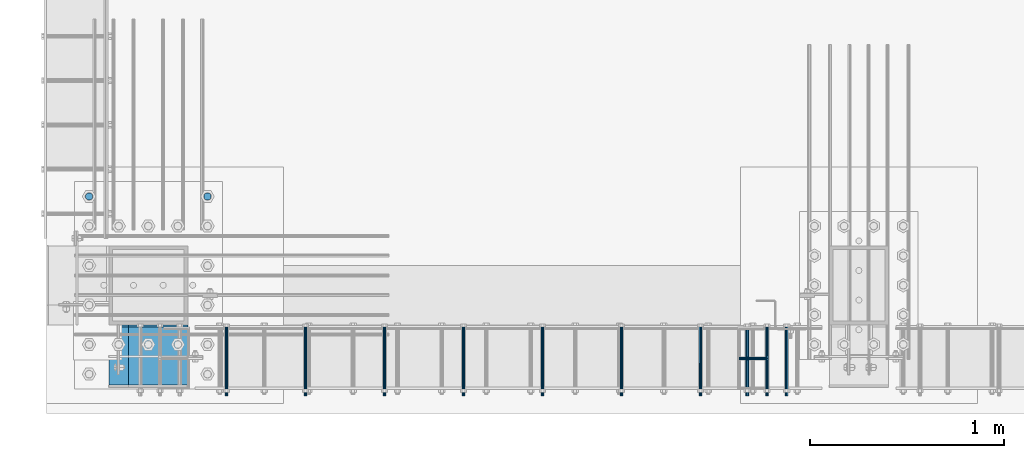
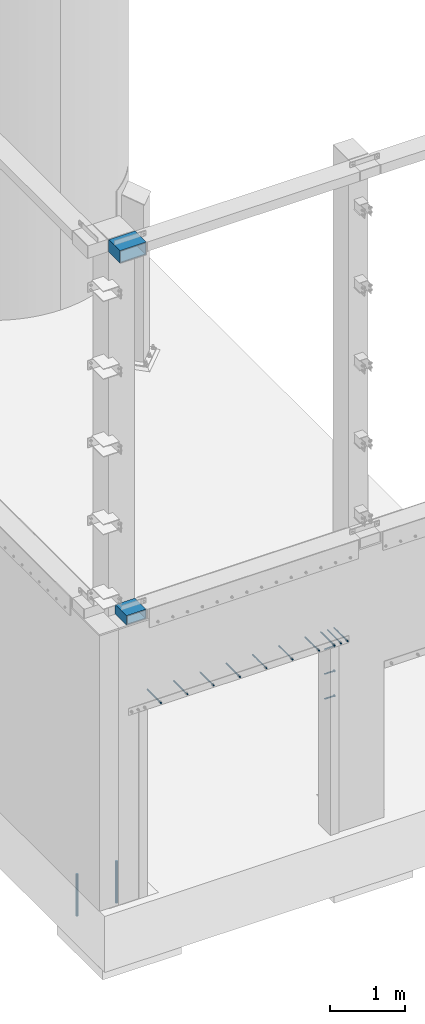
# One storey, part 1083 of 1876: 17 beams, 13 elements without a shape of their own.
"""IFC2X3 building model written with IfcOpenShell, lengths in millimetres."""

from ifc_helpers import new_model, si_unit, frame, origin_with_axes, place, context, subcontext, project, spatial, faceted_brep, material, type_object, element, aggregate, save


model = new_model("IFC2X3")

# Units and contexts
model_context = context("Model", 3, precision=1e-05, world=origin_with_axes())
body_context = subcontext(model_context, "Body", "Model", "MODEL_VIEW")
ifc_project = project(units=[si_unit("LENGTHUNIT", "METRE", prefix="MILLI"), si_unit("AREAUNIT", "SQUARE_METRE"), si_unit("VOLUMEUNIT", "CUBIC_METRE"), si_unit("MASSUNIT", "GRAM", prefix="KILO"), si_unit("TIMEUNIT", "SECOND"), si_unit("PLANEANGLEUNIT", "RADIAN"), si_unit("SOLIDANGLEUNIT", "STERADIAN"), si_unit("THERMODYNAMICTEMPERATUREUNIT", "DEGREE_CELSIUS"), si_unit("LUMINOUSINTENSITYUNIT", "LUMEN")], contexts=[model_context])

# Site, building, storey
site_placement = place(None, origin_with_axes())
site = spatial("IfcSite", under=ifc_project, at=site_placement, CompositionType="ELEMENT")
building_placement = place(site_placement, origin_with_axes())
building = spatial("IfcBuilding", under=site, at=building_placement, Name="Undefined", CompositionType="ELEMENT")
storey_placement = place(building_placement, origin_with_axes())
storey = spatial("IfcBuildingStorey", under=building, at=storey_placement, Name="Undefined", CompositionType="ELEMENT", Elevation=0.0)

# Assembly, beam
assembly_1_placement = place(storey_placement, origin_with_axes())
assembly_1 = element("IfcElementAssembly", 1, at=assembly_1_placement, inside=storey, Name="COLUMN", AssemblyPlace="NOTDEFINED", PredefinedType="RIGID_FRAME")
ifc_material_1 = material()
beam_type_1 = type_object("IfcBeamType", Name="HSS12X6X1/2", PredefinedType="NOTDEFINED")
beam_1_placement = place(assembly_1_placement, frame((282.574999999999, -25923.875, 4597.4), z_axis=(-1.0, 0.0, 0.0), x_axis=(0.0, 1.0, 0.0)))
beam_1 = element("IfcBeam", 2, at=beam_1_placement, type_object=beam_type_1, material=ifc_material_1, Name="BEAM", ObjectType="HSS12X6X1/2", context=body_context, shape_type="Brep", body=[
    faceted_brep([(9.52499999999452, -76.1999999999998, 152.400000000001), (9.52499999999452, -76.1999999999998, -152.400000000001), (307.975000000006, -76.1999999999998, -152.400000000001), (307.975000000006, -76.1999999999998, 152.400000000001), (9.52499999999452, 76.1999999999998, 152.400000000001), (9.52499999999452, 76.1999999999998, -152.400000000001), (9.52499999999452, 63.5, 139.700000000001), (9.52499999999452, -63.5, 139.700000000001), (9.52499999999452, -63.5, -139.700000000001), (9.52499999999452, 63.5, -139.700000000001), (320.675000000004, -63.5, 139.700000000001), (320.675000000004, -63.5, -139.700000000001), (320.675000000004, -63.5000000000018, -152.400000000001), (320.675000000004, -63.5000000000018, 152.400000000001), (320.675000000004, 63.5000000000073, 152.400000000001), (308.334731518538, 76.1999999999998, 152.4), (308.334731518538, 76.1999999999998, -152.4), (320.675000000004, 63.5000000000073, -152.400000000001), (320.675000000004, 63.5, -139.700000000001), (320.675000000004, 63.5, 139.700000000001)], [[[0, 1, 2, 3]], [[1, 0, 4, 5], [6, 7, 8, 9]], [[8, 7, 10, 11]], [[2, 12, 11, 10, 13, 3]], [[4, 0, 3, 13, 14, 15]], [[5, 4, 15, 16]], [[12, 2, 1, 5, 16, 17]], [[17, 18, 11, 12]], [[9, 8, 11, 18]], [[6, 9, 18, 19]], [[7, 6, 19, 10]], [[19, 14, 13, 10]], [[18, 17, 16, 15, 14, 19]]]),
])

assembly_2_placement = place(storey_placement, origin_with_axes())
assembly_2 = element("IfcElementAssembly", 3, at=assembly_2_placement, inside=storey, Name="ANCHOR_BOLT", AssemblyPlace="NOTDEFINED", PredefinedType="RIGID_FRAME")
ifc_material_2 = material(Name="STEEL/A36")
beam_type_2 = type_object("IfcBeamType", PredefinedType="NOTDEFINED")
beam_2_placement = place(assembly_2_placement, frame((3517.90097706187, -25969.9124996982, 3103.56250152592), z_axis=(0.0, 0.0, 1.0), x_axis=(-2.91149999876944e-05, 0.999999999576158, 0.0)))
beam_2 = element("IfcBeam", 4, at=beam_2_placement, type_object=beam_type_2, material=ifc_material_2, Name="ANCHOR_BOLT", context=body_context, shape_type="Brep", body=[
    faceted_brep([(0.0, -7.9375, 0.0), (0.0, -5.61266007566822, -5.61266007566883), (369.887490732475, -5.61266007567792, -5.61266007566837), (369.887490732477, -7.93750000000978, 0.0), (0.0, 0.0, -7.9375), (369.88749073247, -9.54969436861575e-12, -7.9375), (0.0, 5.61266007566822, -5.61266007566883), (369.887490732464, 5.6126600756586, -5.61266007566837), (0.0, 7.9375, 0.0), (369.887490732463, 7.93749999999045, 0.0), (0.0, 5.61266007566822, 5.61266007566883), (369.887490732464, 5.6126600756586, 5.61266007566837), (0.0, 0.0, 7.9375), (369.88749073247, -9.54969436861575e-12, 7.9375), (0.0, -5.61266007566822, 5.61266007566883), (369.887490732475, -5.61266007567792, 5.61266007566837)], [[[0, 1, 2, 3]], [[1, 4, 5, 2]], [[4, 6, 7, 5]], [[6, 8, 9, 7]], [[8, 10, 11, 9]], [[10, 12, 13, 11]], [[12, 14, 15, 13]], [[14, 0, 3, 15]], [[5, 7, 9, 11, 13, 15, 3, 2]], [[14, 12, 10, 8, 6, 4, 1, 0]]]),
])
aggregate(assembly_2, [beam_2])

assembly_3_placement = place(storey_placement, origin_with_axes())
assembly_3 = element("IfcElementAssembly", 5, at=assembly_3_placement, inside=storey, Name="ANCHOR_BOLT", AssemblyPlace="NOTDEFINED", PredefinedType="RIGID_FRAME")
beam_3_placement = place(assembly_3_placement, frame((3416.30097706187, -25969.9124996982, 3103.56250152592), z_axis=(0.0, 0.0, 1.0), x_axis=(-2.91149999876944e-05, 0.999999999576158, 0.0)))
beam_3 = element("IfcBeam", 6, at=beam_3_placement, type_object=beam_type_2, material=ifc_material_2, Name="ANCHOR_BOLT", context=body_context, shape_type="Brep", body=[
    faceted_brep([(0.0, -7.9375, 0.0), (0.0, -5.61266007566822, -5.61266007566883), (369.887490732475, -5.61266007567792, -5.61266007566837), (369.887490732477, -7.93750000000978, 0.0), (0.0, 0.0, -7.9375), (369.88749073247, -9.54969436861575e-12, -7.9375), (0.0, 5.61266007566822, -5.61266007566883), (369.887490732464, 5.6126600756586, -5.61266007566837), (0.0, 7.9375, 0.0), (369.887490732463, 7.93749999999045, 0.0), (0.0, 5.61266007566822, 5.61266007566883), (369.887490732464, 5.6126600756586, 5.61266007566837), (0.0, 0.0, 7.9375), (369.88749073247, -9.54969436861575e-12, 7.9375), (0.0, -5.61266007566822, 5.61266007566883), (369.887490732475, -5.61266007567792, 5.61266007566837)], [[[0, 1, 2, 3]], [[1, 4, 5, 2]], [[4, 6, 7, 5]], [[6, 8, 9, 7]], [[8, 10, 11, 9]], [[10, 12, 13, 11]], [[12, 14, 15, 13]], [[14, 0, 3, 15]], [[5, 7, 9, 11, 13, 15, 3, 2]], [[14, 12, 10, 8, 6, 4, 1, 0]]]),
])
aggregate(assembly_3, [beam_3])

assembly_4_placement = place(storey_placement, origin_with_axes())
assembly_4 = element("IfcElementAssembly", 7, at=assembly_4_placement, inside=storey, Name="ANCHOR_BOLT", AssemblyPlace="NOTDEFINED", PredefinedType="RIGID_FRAME")
beam_4_placement = place(assembly_4_placement, frame((3314.70097706187, -25969.9124996982, 3103.56250152592), z_axis=(0.0, 0.0, 1.0), x_axis=(-2.91149999876944e-05, 0.999999999576158, 0.0)))
beam_4 = element("IfcBeam", 8, at=beam_4_placement, type_object=beam_type_2, material=ifc_material_2, Name="ANCHOR_BOLT", context=body_context, shape_type="Brep", body=[
    faceted_brep([(0.0, -7.9375, 0.0), (0.0, -5.61266007566822, -5.61266007566883), (369.887490732475, -5.61266007567792, -5.61266007566837), (369.887490732477, -7.93750000000978, 0.0), (0.0, 0.0, -7.9375), (369.88749073247, -9.54969436861575e-12, -7.9375), (0.0, 5.61266007566822, -5.61266007566883), (369.887490732464, 5.6126600756586, -5.61266007566837), (0.0, 7.9375, 0.0), (369.887490732463, 7.93749999999045, 0.0), (0.0, 5.61266007566822, 5.61266007566883), (369.887490732464, 5.6126600756586, 5.61266007566837), (0.0, 0.0, 7.9375), (369.88749073247, -9.54969436861575e-12, 7.9375), (0.0, -5.61266007566822, 5.61266007566883), (369.887490732475, -5.61266007567792, 5.61266007566837)], [[[0, 1, 2, 3]], [[1, 4, 5, 2]], [[4, 6, 7, 5]], [[6, 8, 9, 7]], [[8, 10, 11, 9]], [[10, 12, 13, 11]], [[12, 14, 15, 13]], [[14, 0, 3, 15]], [[5, 7, 9, 11, 13, 15, 3, 2]], [[14, 12, 10, 8, 6, 4, 1, 0]]]),
])
aggregate(assembly_4, [beam_4])

assembly_5_placement = place(storey_placement, origin_with_axes())
assembly_5 = element("IfcElementAssembly", 9, at=assembly_5_placement, inside=storey, Name="ANCHOR_BOLT", AssemblyPlace="NOTDEFINED", PredefinedType="RIGID_FRAME")
beam_5_placement = place(assembly_5_placement, frame((3073.40097706187, -25969.9124996982, 3103.56250152592), z_axis=(0.0, 0.0, 1.0), x_axis=(-2.91149999876944e-05, 0.999999999576158, 0.0)))
beam_5 = element("IfcBeam", 10, at=beam_5_placement, type_object=beam_type_2, material=ifc_material_2, Name="ANCHOR_BOLT", context=body_context, shape_type="Brep", body=[
    faceted_brep([(0.0, -7.9375, 0.0), (0.0, -5.61266007566822, -5.61266007566883), (369.887490732475, -5.61266007567792, -5.61266007566837), (369.887490732477, -7.93750000000978, 0.0), (0.0, 0.0, -7.9375), (369.88749073247, -9.54969436861575e-12, -7.9375), (0.0, 5.61266007566822, -5.61266007566883), (369.887490732464, 5.6126600756586, -5.61266007566837), (0.0, 7.9375, 0.0), (369.887490732463, 7.93749999999045, 0.0), (0.0, 5.61266007566822, 5.61266007566883), (369.887490732464, 5.6126600756586, 5.61266007566837), (0.0, 0.0, 7.9375), (369.88749073247, -9.54969436861575e-12, 7.9375), (0.0, -5.61266007566822, 5.61266007566883), (369.887490732475, -5.61266007567792, 5.61266007566837)], [[[0, 1, 2, 3]], [[1, 4, 5, 2]], [[4, 6, 7, 5]], [[6, 8, 9, 7]], [[8, 10, 11, 9]], [[10, 12, 13, 11]], [[12, 14, 15, 13]], [[14, 0, 3, 15]], [[5, 7, 9, 11, 13, 15, 3, 2]], [[14, 12, 10, 8, 6, 4, 1, 0]]]),
])
aggregate(assembly_5, [beam_5])

assembly_6_placement = place(storey_placement, origin_with_axes())
assembly_6 = element("IfcElementAssembly", 11, at=assembly_6_placement, inside=storey, Name="ANCHOR_BOLT", AssemblyPlace="NOTDEFINED", PredefinedType="RIGID_FRAME")
beam_6_placement = place(assembly_6_placement, frame((2667.00097706187, -25969.9124996982, 3103.56250152592), z_axis=(0.0, 0.0, 1.0), x_axis=(-2.91149999876944e-05, 0.999999999576158, 0.0)))
beam_6 = element("IfcBeam", 12, at=beam_6_placement, type_object=beam_type_2, material=ifc_material_2, Name="ANCHOR_BOLT", context=body_context, shape_type="Brep", body=[
    faceted_brep([(0.0, -7.9375, 0.0), (0.0, -5.61266007566822, -5.61266007566883), (369.887490732475, -5.61266007567792, -5.61266007566837), (369.887490732477, -7.93750000000978, 0.0), (0.0, 0.0, -7.9375), (369.88749073247, -9.54969436861575e-12, -7.9375), (0.0, 5.61266007566822, -5.61266007566883), (369.887490732464, 5.6126600756586, -5.61266007566837), (0.0, 7.9375, 0.0), (369.887490732463, 7.93749999999045, 0.0), (0.0, 5.61266007566822, 5.61266007566883), (369.887490732464, 5.6126600756586, 5.61266007566837), (0.0, 0.0, 7.9375), (369.88749073247, -9.54969436861575e-12, 7.9375), (0.0, -5.61266007566822, 5.61266007566883), (369.887490732475, -5.61266007567792, 5.61266007566837)], [[[0, 1, 2, 3]], [[1, 4, 5, 2]], [[4, 6, 7, 5]], [[6, 8, 9, 7]], [[8, 10, 11, 9]], [[10, 12, 13, 11]], [[12, 14, 15, 13]], [[14, 0, 3, 15]], [[5, 7, 9, 11, 13, 15, 3, 2]], [[14, 12, 10, 8, 6, 4, 1, 0]]]),
])
aggregate(assembly_6, [beam_6])

assembly_7_placement = place(storey_placement, origin_with_axes())
assembly_7 = element("IfcElementAssembly", 13, at=assembly_7_placement, inside=storey, Name="ANCHOR_BOLT", AssemblyPlace="NOTDEFINED", PredefinedType="RIGID_FRAME")
beam_7_placement = place(assembly_7_placement, frame((2260.60097706187, -25969.9124996982, 3103.56250152592), z_axis=(0.0, 0.0, 1.0), x_axis=(-2.91149999876944e-05, 0.999999999576158, 0.0)))
beam_7 = element("IfcBeam", 14, at=beam_7_placement, type_object=beam_type_2, material=ifc_material_2, Name="ANCHOR_BOLT", context=body_context, shape_type="Brep", body=[
    faceted_brep([(0.0, -7.9375, 0.0), (0.0, -5.61266007566822, -5.61266007566883), (369.887490732475, -5.61266007567792, -5.61266007566837), (369.887490732477, -7.93750000000978, 0.0), (0.0, 0.0, -7.9375), (369.88749073247, -9.54969436861575e-12, -7.9375), (0.0, 5.61266007566822, -5.61266007566883), (369.887490732464, 5.6126600756586, -5.61266007566837), (0.0, 7.9375, 0.0), (369.887490732463, 7.93749999999045, 0.0), (0.0, 5.61266007566822, 5.61266007566883), (369.887490732464, 5.6126600756586, 5.61266007566837), (0.0, 0.0, 7.9375), (369.88749073247, -9.54969436861575e-12, 7.9375), (0.0, -5.61266007566822, 5.61266007566883), (369.887490732475, -5.61266007567792, 5.61266007566837)], [[[0, 1, 2, 3]], [[1, 4, 5, 2]], [[4, 6, 7, 5]], [[6, 8, 9, 7]], [[8, 10, 11, 9]], [[10, 12, 13, 11]], [[12, 14, 15, 13]], [[14, 0, 3, 15]], [[5, 7, 9, 11, 13, 15, 3, 2]], [[14, 12, 10, 8, 6, 4, 1, 0]]]),
])
aggregate(assembly_7, [beam_7])

assembly_8_placement = place(storey_placement, origin_with_axes())
assembly_8 = element("IfcElementAssembly", 15, at=assembly_8_placement, inside=storey, Name="ANCHOR_BOLT", AssemblyPlace="NOTDEFINED", PredefinedType="RIGID_FRAME")
beam_8_placement = place(assembly_8_placement, frame((1854.20097706187, -25969.9124996982, 3103.56250152592), z_axis=(0.0, 0.0, 1.0), x_axis=(-2.91149999876944e-05, 0.999999999576158, 0.0)))
beam_8 = element("IfcBeam", 16, at=beam_8_placement, type_object=beam_type_2, material=ifc_material_2, Name="ANCHOR_BOLT", context=body_context, shape_type="Brep", body=[
    faceted_brep([(0.0, -7.9375, 0.0), (0.0, -5.61266007566822, -5.61266007566883), (369.887490732475, -5.61266007567792, -5.61266007566837), (369.887490732477, -7.93750000000978, 0.0), (0.0, 0.0, -7.9375), (369.88749073247, -9.54969436861575e-12, -7.9375), (0.0, 5.61266007566822, -5.61266007566883), (369.887490732464, 5.6126600756586, -5.61266007566837), (0.0, 7.9375, 0.0), (369.887490732463, 7.93749999999045, 0.0), (0.0, 5.61266007566822, 5.61266007566883), (369.887490732464, 5.6126600756586, 5.61266007566837), (0.0, 0.0, 7.9375), (369.88749073247, -9.54969436861575e-12, 7.9375), (0.0, -5.61266007566822, 5.61266007566883), (369.887490732475, -5.61266007567792, 5.61266007566837)], [[[0, 1, 2, 3]], [[1, 4, 5, 2]], [[4, 6, 7, 5]], [[6, 8, 9, 7]], [[8, 10, 11, 9]], [[10, 12, 13, 11]], [[12, 14, 15, 13]], [[14, 0, 3, 15]], [[5, 7, 9, 11, 13, 15, 3, 2]], [[14, 12, 10, 8, 6, 4, 1, 0]]]),
])
aggregate(assembly_8, [beam_8])

assembly_9_placement = place(storey_placement, origin_with_axes())
assembly_9 = element("IfcElementAssembly", 17, at=assembly_9_placement, inside=storey, Name="ANCHOR_BOLT", AssemblyPlace="NOTDEFINED", PredefinedType="RIGID_FRAME")
beam_9_placement = place(assembly_9_placement, frame((1447.80097706187, -25969.9124996982, 3103.56250152592), z_axis=(0.0, 0.0, 1.0), x_axis=(-2.91149999876944e-05, 0.999999999576158, 0.0)))
beam_9 = element("IfcBeam", 18, at=beam_9_placement, type_object=beam_type_2, material=ifc_material_2, Name="ANCHOR_BOLT", context=body_context, shape_type="Brep", body=[
    faceted_brep([(0.0, -7.9375, 0.0), (0.0, -5.61266007566822, -5.61266007566883), (369.887490732475, -5.61266007567792, -5.61266007566837), (369.887490732477, -7.93750000000978, 0.0), (0.0, 0.0, -7.9375), (369.88749073247, -9.54969436861575e-12, -7.9375), (0.0, 5.61266007566822, -5.61266007566883), (369.887490732464, 5.6126600756586, -5.61266007566837), (0.0, 7.9375, 0.0), (369.887490732463, 7.93749999999045, 0.0), (0.0, 5.61266007566822, 5.61266007566883), (369.887490732464, 5.6126600756586, 5.61266007566837), (0.0, 0.0, 7.9375), (369.88749073247, -9.54969436861575e-12, 7.9375), (0.0, -5.61266007566822, 5.61266007566883), (369.887490732475, -5.61266007567792, 5.61266007566837)], [[[0, 1, 2, 3]], [[1, 4, 5, 2]], [[4, 6, 7, 5]], [[6, 8, 9, 7]], [[8, 10, 11, 9]], [[10, 12, 13, 11]], [[12, 14, 15, 13]], [[14, 0, 3, 15]], [[5, 7, 9, 11, 13, 15, 3, 2]], [[14, 12, 10, 8, 6, 4, 1, 0]]]),
])
aggregate(assembly_9, [beam_9])

assembly_10_placement = place(storey_placement, origin_with_axes())
assembly_10 = element("IfcElementAssembly", 19, at=assembly_10_placement, inside=storey, Name="ANCHOR_BOLT", AssemblyPlace="NOTDEFINED", PredefinedType="RIGID_FRAME")
beam_10_placement = place(assembly_10_placement, frame((1041.40097706187, -25969.9124996982, 3103.56250152592), z_axis=(0.0, 0.0, 1.0), x_axis=(-2.91149999876944e-05, 0.999999999576158, 0.0)))
beam_10 = element("IfcBeam", 20, at=beam_10_placement, type_object=beam_type_2, material=ifc_material_2, Name="ANCHOR_BOLT", context=body_context, shape_type="Brep", body=[
    faceted_brep([(0.0, -7.9375, 0.0), (0.0, -5.61266007566822, -5.61266007566883), (369.887490732475, -5.61266007567792, -5.61266007566837), (369.887490732477, -7.93750000000978, 0.0), (0.0, 0.0, -7.9375), (369.88749073247, -9.54969436861575e-12, -7.9375), (0.0, 5.61266007566822, -5.61266007566883), (369.887490732464, 5.6126600756586, -5.61266007566837), (0.0, 7.9375, 0.0), (369.887490732463, 7.93749999999045, 0.0), (0.0, 5.61266007566822, 5.61266007566883), (369.887490732464, 5.6126600756586, 5.61266007566837), (0.0, 0.0, 7.9375), (369.88749073247, -9.54969436861575e-12, 7.9375), (0.0, -5.61266007566822, 5.61266007566883), (369.887490732475, -5.61266007567792, 5.61266007566837)], [[[0, 1, 2, 3]], [[1, 4, 5, 2]], [[4, 6, 7, 5]], [[6, 8, 9, 7]], [[8, 10, 11, 9]], [[10, 12, 13, 11]], [[12, 14, 15, 13]], [[14, 0, 3, 15]], [[5, 7, 9, 11, 13, 15, 3, 2]], [[14, 12, 10, 8, 6, 4, 1, 0]]]),
])
aggregate(assembly_10, [beam_10])

assembly_11_placement = place(storey_placement, origin_with_axes())
assembly_11 = element("IfcElementAssembly", 21, at=assembly_11_placement, inside=storey, Name="ANCHOR_BOLT", AssemblyPlace="NOTDEFINED", PredefinedType="RIGID_FRAME")
beam_11_placement = place(assembly_11_placement, frame((635.000977061869, -25969.9124996982, 3103.56250152592), z_axis=(0.0, 0.0, 1.0), x_axis=(-2.91149999876944e-05, 0.999999999576158, 0.0)))
beam_11 = element("IfcBeam", 22, at=beam_11_placement, type_object=beam_type_2, material=ifc_material_2, Name="ANCHOR_BOLT", context=body_context, shape_type="Brep", body=[
    faceted_brep([(0.0, -7.9375, 0.0), (0.0, -5.61266007566822, -5.61266007566883), (369.887490732475, -5.61266007567792, -5.61266007566837), (369.887490732477, -7.93750000000978, 0.0), (0.0, 0.0, -7.9375), (369.88749073247, -9.54969436861575e-12, -7.9375), (0.0, 5.61266007566822, -5.61266007566883), (369.887490732464, 5.6126600756586, -5.61266007566837), (0.0, 7.9375, 0.0), (369.887490732463, 7.93749999999045, 0.0), (0.0, 5.61266007566822, 5.61266007566883), (369.887490732464, 5.6126600756586, 5.61266007566837), (0.0, 0.0, 7.9375), (369.88749073247, -9.54969436861575e-12, 7.9375), (0.0, -5.61266007566822, 5.61266007566883), (369.887490732475, -5.61266007567792, 5.61266007566837)], [[[0, 1, 2, 3]], [[1, 4, 5, 2]], [[4, 6, 7, 5]], [[6, 8, 9, 7]], [[8, 10, 11, 9]], [[10, 12, 13, 11]], [[12, 14, 15, 13]], [[14, 0, 3, 15]], [[5, 7, 9, 11, 13, 15, 3, 2]], [[14, 12, 10, 8, 6, 4, 1, 0]]]),
])
aggregate(assembly_11, [beam_11])

# Assembly, beams
assembly_12_placement = place(storey_placement, origin_with_axes())
assembly_12 = element("IfcElementAssembly", 23, at=assembly_12_placement, inside=storey, Name="BENT PLATE", AssemblyPlace="NOTDEFINED", PredefinedType="RIGID_FRAME")
ifc_material_3 = material(Name="STEEL/A108")
beam_type_3 = type_object("IfcBeamType", Name="STUD_5/8-DIA", PredefinedType="NOTDEFINED")
beam_12_placement = place(assembly_12_placement, frame((3271.83899529796, -25776.2375096436, 2946.4), z_axis=(0.0, 0.0, 1.0), x_axis=(1.0, 0.0, 0.0)))
beam_12 = element("IfcBeam", 24, at=beam_12_placement, type_object=beam_type_3, material=ifc_material_3, Name="WELDED HEADED STUD", ObjectType="STUD_5/8-DIA", context=body_context, shape_type="Brep", body=[
    faceted_brep([(0.0, -7.94000005722046, 0.0), (0.0, -6.86999988555908, -3.97000002861023), (140.207082738083, -6.86999988555908, -3.97000002861023), (140.207082738083, -7.94000005722046, 0.0), (0.0, -3.97000002861023, -6.86999988555908), (140.207082738083, -3.97000002861023, -6.86999988555908), (0.0, 0.0, -7.94000005722046), (140.207082738083, 0.0, -7.94000005722046), (0.0, 3.97000002861023, -6.86999988555908), (140.207082738083, 3.97000002861023, -6.86999988555908), (0.0, 6.86999988555908, -3.97000002861023), (140.207082738083, 6.86999988555908, -3.97000002861023), (0.0, 7.94000005722046, 0.0), (140.207082738083, 7.94000005722046, 0.0), (0.0, 6.86999988555908, 3.97000002861023), (140.207082738083, 6.86999988555908, 3.97000002861023), (0.0, 3.97000002861023, 6.86999988555908), (140.207082738083, 3.97000002861023, 6.86999988555908), (0.0, 0.0, 7.94000005722046), (140.207082738083, 0.0, 7.94000005722046), (0.0, -3.97000002861023, 6.86999988555908), (140.207082738083, -3.97000002861023, 6.86999988555908), (0.0, -6.86999988555908, 3.97000002861023), (140.207082738083, -6.86999988555908, 3.97000002861023), (141.731072767845, -13.75, -7.94000005722046), (141.731072767845, -15.8800001144409, 0.0), (141.731072767845, -7.94000005722046, -13.75), (141.731072767845, 0.0, -15.8800001144409), (141.731072767845, 7.94000005722046, -13.75), (141.731072767845, 13.75, -7.94000005722046), (141.731072767845, 15.8800001144409, 0.0), (141.731072767845, 13.75, 7.94000005722046), (141.731072767845, 7.94000005722046, 13.75), (141.731072767845, 0.0, 15.8800001144409), (141.731072767845, -7.94000005722046, 13.75), (141.731072767845, -13.75, 7.94000005722046), (152.399002976177, -13.75, -7.94000005722046), (152.399002976177, -15.8800001144409, 0.0), (152.399002976177, -7.94000005722046, -13.75), (152.399002976177, 0.0, -15.8800001144409), (152.399002976177, 7.94000005722046, -13.75), (152.399002976177, 13.75, -7.94000005722046), (152.399002976177, 15.8800001144409, 0.0), (152.399002976177, 13.75, 7.94000005722046), (152.399002976177, 7.94000005722046, 13.75), (152.399002976177, 0.0, 15.8800001144409), (152.399002976177, -7.94000005722046, 13.75), (152.399002976177, -13.75, 7.94000005722046)], [[[0, 1, 2, 3]], [[1, 4, 5, 2]], [[4, 6, 7, 5]], [[6, 8, 9, 7]], [[8, 10, 11, 9]], [[10, 12, 13, 11]], [[12, 14, 15, 13]], [[14, 16, 17, 15]], [[16, 18, 19, 17]], [[18, 20, 21, 19]], [[20, 22, 23, 21]], [[22, 0, 3, 23]], [[22, 20, 18, 16, 14, 12, 10, 8, 6, 4, 1, 0]], [[3, 2, 24, 25]], [[2, 5, 26, 24]], [[5, 7, 27, 26]], [[7, 9, 28, 27]], [[9, 11, 29, 28]], [[11, 13, 30, 29]], [[13, 15, 31, 30]], [[15, 17, 32, 31]], [[17, 19, 33, 32]], [[19, 21, 34, 33]], [[21, 23, 35, 34]], [[23, 3, 25, 35]], [[25, 24, 36, 37]], [[24, 26, 38, 36]], [[26, 27, 39, 38]], [[27, 28, 40, 39]], [[28, 29, 41, 40]], [[29, 30, 42, 41]], [[30, 31, 43, 42]], [[31, 32, 44, 43]], [[32, 33, 45, 44]], [[33, 34, 46, 45]], [[34, 35, 47, 46]], [[35, 25, 37, 47]], [[38, 39, 40, 41, 42, 43, 44, 45, 46, 47, 37, 36]]]),
])
beam_13_placement = place(assembly_12_placement, frame((3271.83899529796, -25776.2375096436, 2540.0), z_axis=(0.0, 0.0, 1.0), x_axis=(1.0, 0.0, 0.0)))
beam_13 = element("IfcBeam", 25, at=beam_13_placement, type_object=beam_type_3, material=ifc_material_3, Name="WELDED HEADED STUD", ObjectType="STUD_5/8-DIA", context=body_context, shape_type="Brep", body=[
    faceted_brep([(0.0, -7.94000005722046, 0.0), (0.0, -6.86999988555908, -3.97000002861023), (140.207082738083, -6.86999988555908, -3.97000002861023), (140.207082738083, -7.94000005722046, 0.0), (0.0, -3.97000002861023, -6.86999988555908), (140.207082738083, -3.97000002861023, -6.86999988555908), (0.0, 0.0, -7.94000005722046), (140.207082738083, 0.0, -7.94000005722046), (0.0, 3.97000002861023, -6.86999988555908), (140.207082738083, 3.97000002861023, -6.86999988555908), (0.0, 6.86999988555908, -3.97000002861023), (140.207082738083, 6.86999988555908, -3.97000002861023), (0.0, 7.94000005722046, 0.0), (140.207082738083, 7.94000005722046, 0.0), (0.0, 6.86999988555908, 3.97000002861023), (140.207082738083, 6.86999988555908, 3.97000002861023), (0.0, 3.97000002861023, 6.86999988555908), (140.207082738083, 3.97000002861023, 6.86999988555908), (0.0, 0.0, 7.94000005722046), (140.207082738083, 0.0, 7.94000005722046), (0.0, -3.97000002861023, 6.86999988555908), (140.207082738083, -3.97000002861023, 6.86999988555908), (0.0, -6.86999988555908, 3.97000002861023), (140.207082738083, -6.86999988555908, 3.97000002861023), (141.731072767845, -13.75, -7.94000005722046), (141.731072767845, -15.8800001144409, 0.0), (141.731072767845, -7.94000005722046, -13.75), (141.731072767845, 0.0, -15.8800001144409), (141.731072767845, 7.94000005722046, -13.75), (141.731072767845, 13.75, -7.94000005722046), (141.731072767845, 15.8800001144409, 0.0), (141.731072767845, 13.75, 7.94000005722046), (141.731072767845, 7.94000005722046, 13.75), (141.731072767845, 0.0, 15.8800001144409), (141.731072767845, -7.94000005722046, 13.75), (141.731072767845, -13.75, 7.94000005722046), (152.399002976177, -13.75, -7.94000005722046), (152.399002976177, -15.8800001144409, 0.0), (152.399002976177, -7.94000005722046, -13.75), (152.399002976177, 0.0, -15.8800001144409), (152.399002976177, 7.94000005722046, -13.75), (152.399002976177, 13.75, -7.94000005722046), (152.399002976177, 15.8800001144409, 0.0), (152.399002976177, 13.75, 7.94000005722046), (152.399002976177, 7.94000005722046, 13.75), (152.399002976177, 0.0, 15.8800001144409), (152.399002976177, -7.94000005722046, 13.75), (152.399002976177, -13.75, 7.94000005722046)], [[[0, 1, 2, 3]], [[1, 4, 5, 2]], [[4, 6, 7, 5]], [[6, 8, 9, 7]], [[8, 10, 11, 9]], [[10, 12, 13, 11]], [[12, 14, 15, 13]], [[14, 16, 17, 15]], [[16, 18, 19, 17]], [[18, 20, 21, 19]], [[20, 22, 23, 21]], [[22, 0, 3, 23]], [[22, 20, 18, 16, 14, 12, 10, 8, 6, 4, 1, 0]], [[3, 2, 24, 25]], [[2, 5, 26, 24]], [[5, 7, 27, 26]], [[7, 9, 28, 27]], [[9, 11, 29, 28]], [[11, 13, 30, 29]], [[13, 15, 31, 30]], [[15, 17, 32, 31]], [[17, 19, 33, 32]], [[19, 21, 34, 33]], [[21, 23, 35, 34]], [[23, 3, 25, 35]], [[25, 24, 36, 37]], [[24, 26, 38, 36]], [[26, 27, 39, 38]], [[27, 28, 40, 39]], [[28, 29, 41, 40]], [[29, 30, 42, 41]], [[30, 31, 43, 42]], [[31, 32, 44, 43]], [[32, 33, 45, 44]], [[33, 34, 46, 45]], [[34, 35, 47, 46]], [[35, 25, 37, 47]], [[38, 39, 40, 41, 42, 43, 44, 45, 46, 47, 37, 36]]]),
])
beam_14_placement = place(assembly_12_placement, frame((3271.83899529796, -25776.2375096436, 2133.6), z_axis=(0.0, 0.0, 1.0), x_axis=(1.0, 0.0, 0.0)))
beam_14 = element("IfcBeam", 26, at=beam_14_placement, type_object=beam_type_3, material=ifc_material_3, Name="WELDED HEADED STUD", ObjectType="STUD_5/8-DIA", context=body_context, shape_type="Brep", body=[
    faceted_brep([(0.0, -7.94000005722046, 0.0), (0.0, -6.86999988555908, -3.97000002861023), (140.207082738083, -6.86999988555908, -3.97000002861023), (140.207082738083, -7.94000005722046, 0.0), (0.0, -3.97000002861023, -6.86999988555908), (140.207082738083, -3.97000002861023, -6.86999988555908), (0.0, 0.0, -7.94000005722046), (140.207082738083, 0.0, -7.94000005722046), (0.0, 3.97000002861023, -6.86999988555908), (140.207082738083, 3.97000002861023, -6.86999988555908), (0.0, 6.86999988555908, -3.97000002861023), (140.207082738083, 6.86999988555908, -3.97000002861023), (0.0, 7.94000005722046, 0.0), (140.207082738083, 7.94000005722046, 0.0), (0.0, 6.86999988555908, 3.97000002861023), (140.207082738083, 6.86999988555908, 3.97000002861023), (0.0, 3.97000002861023, 6.86999988555908), (140.207082738083, 3.97000002861023, 6.86999988555908), (0.0, 0.0, 7.94000005722046), (140.207082738083, 0.0, 7.94000005722046), (0.0, -3.97000002861023, 6.86999988555908), (140.207082738083, -3.97000002861023, 6.86999988555908), (0.0, -6.86999988555908, 3.97000002861023), (140.207082738083, -6.86999988555908, 3.97000002861023), (141.731072767845, -13.75, -7.94000005722046), (141.731072767845, -15.8800001144409, 0.0), (141.731072767845, -7.94000005722046, -13.75), (141.731072767845, 0.0, -15.8800001144409), (141.731072767845, 7.94000005722046, -13.75), (141.731072767845, 13.75, -7.94000005722046), (141.731072767845, 15.8800001144409, 0.0), (141.731072767845, 13.75, 7.94000005722046), (141.731072767845, 7.94000005722046, 13.75), (141.731072767845, 0.0, 15.8800001144409), (141.731072767845, -7.94000005722046, 13.75), (141.731072767845, -13.75, 7.94000005722046), (152.399002976177, -13.75, -7.94000005722046), (152.399002976177, -15.8800001144409, 0.0), (152.399002976177, -7.94000005722046, -13.75), (152.399002976177, 0.0, -15.8800001144409), (152.399002976177, 7.94000005722046, -13.75), (152.399002976177, 13.75, -7.94000005722046), (152.399002976177, 15.8800001144409, 0.0), (152.399002976177, 13.75, 7.94000005722046), (152.399002976177, 7.94000005722046, 13.75), (152.399002976177, 0.0, 15.8800001144409), (152.399002976177, -7.94000005722046, 13.75), (152.399002976177, -13.75, 7.94000005722046)], [[[0, 1, 2, 3]], [[1, 4, 5, 2]], [[4, 6, 7, 5]], [[6, 8, 9, 7]], [[8, 10, 11, 9]], [[10, 12, 13, 11]], [[12, 14, 15, 13]], [[14, 16, 17, 15]], [[16, 18, 19, 17]], [[18, 20, 21, 19]], [[20, 22, 23, 21]], [[22, 0, 3, 23]], [[22, 20, 18, 16, 14, 12, 10, 8, 6, 4, 1, 0]], [[3, 2, 24, 25]], [[2, 5, 26, 24]], [[5, 7, 27, 26]], [[7, 9, 28, 27]], [[9, 11, 29, 28]], [[11, 13, 30, 29]], [[13, 15, 31, 30]], [[15, 17, 32, 31]], [[17, 19, 33, 32]], [[19, 21, 34, 33]], [[21, 23, 35, 34]], [[23, 3, 25, 35]], [[25, 24, 36, 37]], [[24, 26, 38, 36]], [[26, 27, 39, 38]], [[27, 28, 40, 39]], [[28, 29, 41, 40]], [[29, 30, 42, 41]], [[30, 31, 43, 42]], [[31, 32, 44, 43]], [[32, 33, 45, 44]], [[33, 34, 46, 45]], [[34, 35, 47, 46]], [[35, 25, 37, 47]], [[38, 39, 40, 41, 42, 43, 44, 45, 46, 47, 37, 36]]]),
])
aggregate(assembly_12, [beam_12, beam_13, beam_14])

# Beam
beam_type_4 = type_object("IfcBeamType", Name="HSS16X8X1/2", PredefinedType="NOTDEFINED")
beam_15_placement = place(assembly_1_placement, frame((231.774999999999, -25933.4, 10566.4), z_axis=(-1.0, 0.0, 0.0), x_axis=(0.0, 1.0, 0.0)))
beam_15 = element("IfcBeam", 27, at=beam_15_placement, type_object=beam_type_4, material=ifc_material_1, Name="BEAM", ObjectType="HSS16X8X1/2", context=body_context, shape_type="Brep", body=[
    faceted_brep([(330.200000000004, 88.8999999999978, 203.2), (330.200000000004, 88.8999999999996, 190.5), (330.200000000004, 88.8999999999996, -190.5), (330.200000000004, 88.8999999999978, -203.2), (318.105151367192, 101.6, -203.2), (318.105151367192, 101.6, 203.2), (19.0499999999993, -101.6, 203.2), (19.0499999999993, -101.6, -203.2), (318.105151367192, -101.6, -203.2), (318.105151367192, -101.6, 203.2), (19.0499999999993, 101.6, 203.2), (19.0499999999993, 101.6, -203.2), (19.0499999999993, 88.8999999999996, 190.5), (19.0499999999993, -88.8999999999996, 190.5), (19.0499999999993, -88.8999999999996, -190.5), (19.0499999999993, 88.8999999999996, -190.5), (330.200000000004, -88.8999999999996, 190.5), (330.200000000004, -88.8999999999996, -190.5), (330.200000000004, -88.9000000000015, 203.2), (330.200000000004, -88.9000000000015, -203.2)], [[[0, 1, 2, 3, 4, 5]], [[6, 7, 8, 9]], [[7, 6, 10, 11], [12, 13, 14, 15]], [[14, 13, 16, 17]], [[18, 9, 8, 19, 17, 16]], [[10, 6, 9, 18, 0, 5]], [[11, 10, 5, 4]], [[19, 8, 7, 11, 4, 3]], [[17, 19, 3, 2]], [[15, 14, 17, 2]], [[12, 15, 2, 1]], [[13, 12, 1, 16]], [[18, 16, 1, 0]]]),
])

aggregate(assembly_1, [beam_15, beam_1])

# Assembly, beams
assembly_13_placement = place(storey_placement, origin_with_axes())
assembly_13 = element("IfcElementAssembly", 28, at=assembly_13_placement, inside=storey, Name="PLATE", AssemblyPlace="NOTDEFINED", PredefinedType="RIGID_FRAME")
ifc_material_4 = material(Name="STEEL/F1554-55, S1")
beam_type_5 = type_object("IfcBeamType", PredefinedType="NOTDEFINED")
beam_16_placement = place(assembly_13_placement, frame((-73.0250005657348, -24942.8000054939, -57.1499999999993), z_axis=(0.0, -1.0, 0.0), x_axis=(0.0, 0.0, -1.0)))
beam_16 = element("IfcBeam", 29, at=beam_16_placement, type_object=beam_type_5, material=ifc_material_4, Name="WELDED ANCHORS", context=body_context, shape_type="Brep", body=[
    faceted_brep([(0.0, -19.0500000000002, 0.0), (0.0, -16.4977839420935, -9.52500000000146), (685.799999999999, -16.4977839420936, -9.52500000000146), (685.799999999999, -19.05, 0.0), (0.0, -9.52500000000009, -16.4977839420935), (685.799999999999, -9.52499999999998, -16.4977839420935), (0.0, 0.0, -19.05), (685.799999999999, 0.0, -19.0499999999993), (0.0, 9.52500000000009, -16.4977839420935), (685.799999999999, 9.52500000000003, -16.4977839420935), (0.0, 16.4977839420935, -9.52500000000146), (685.799999999999, 16.4977839420936, -9.52500000000146), (-9.09494701772928e-13, 19.05, -1.81898940354586e-12), (685.799999999999, 19.05, 0.0), (0.0, 16.4977839420935, 9.52500000000146), (685.799999999999, 16.4977839420936, 9.52500000000146), (0.0, 9.52500000000009, 16.4977839420935), (685.799999999999, 9.52499999999998, 16.4977839420935), (0.0, 0.0, 19.0499999999993), (685.799999999999, 0.0, 19.0499999999993), (0.0, -9.52500000000009, 16.4977839420935), (685.799999999999, -9.52499999999998, 16.4977839420935), (0.0, -16.4977839420935, 9.52500000000146), (685.799999999999, -16.4977839420936, 9.52500000000146)], [[[0, 1, 2, 3]], [[1, 4, 5, 2]], [[4, 6, 7, 5]], [[6, 8, 9, 7]], [[8, 10, 11, 9]], [[10, 12, 13, 11]], [[12, 14, 15, 13]], [[14, 16, 17, 15]], [[16, 18, 19, 17]], [[18, 20, 21, 19]], [[20, 22, 23, 21]], [[22, 0, 3, 23]], [[5, 7, 9, 11, 13, 15, 17, 19, 21, 23, 3, 2]], [[22, 20, 18, 16, 14, 12, 10, 8, 6, 4, 1, 0]]]),
])
beam_17_placement = place(assembly_13_placement, frame((536.574999931718, -24942.8000000075, -57.1499999999993), z_axis=(0.0, -1.0, 0.0), x_axis=(0.0, 0.0, -1.0)))
beam_17 = element("IfcBeam", 30, at=beam_17_placement, type_object=beam_type_5, material=ifc_material_4, Name="WELDED ANCHORS", context=body_context, shape_type="Brep", body=[
    faceted_brep([(0.0, -19.0500000000002, 0.0), (0.0, -16.4977839420935, -9.52500000000146), (685.799999999999, -16.4977839420936, -9.52500000000146), (685.799999999999, -19.05, 0.0), (0.0, -9.52500000000009, -16.4977839420935), (685.799999999999, -9.52499999999998, -16.4977839420935), (0.0, 0.0, -19.05), (685.799999999999, 0.0, -19.0499999999993), (0.0, 9.52500000000009, -16.4977839420935), (685.799999999999, 9.52500000000003, -16.4977839420935), (0.0, 16.4977839420935, -9.52500000000146), (685.799999999999, 16.4977839420936, -9.52500000000146), (-9.09494701772928e-13, 19.05, -1.81898940354586e-12), (685.799999999999, 19.05, 0.0), (0.0, 16.4977839420935, 9.52500000000146), (685.799999999999, 16.4977839420936, 9.52500000000146), (0.0, 9.52500000000009, 16.4977839420935), (685.799999999999, 9.52499999999998, 16.4977839420935), (0.0, 0.0, 19.0499999999993), (685.799999999999, 0.0, 19.0499999999993), (0.0, -9.52500000000009, 16.4977839420935), (685.799999999999, -9.52499999999998, 16.4977839420935), (0.0, -16.4977839420935, 9.52500000000146), (685.799999999999, -16.4977839420936, 9.52500000000146)], [[[0, 1, 2, 3]], [[1, 4, 5, 2]], [[4, 6, 7, 5]], [[6, 8, 9, 7]], [[8, 10, 11, 9]], [[10, 12, 13, 11]], [[12, 14, 15, 13]], [[14, 16, 17, 15]], [[16, 18, 19, 17]], [[18, 20, 21, 19]], [[20, 22, 23, 21]], [[22, 0, 3, 23]], [[5, 7, 9, 11, 13, 15, 17, 19, 21, 23, 3, 2]], [[22, 20, 18, 16, 14, 12, 10, 8, 6, 4, 1, 0]]]),
])
aggregate(assembly_13, [beam_16, beam_17])

save(model, "model.ifc")
